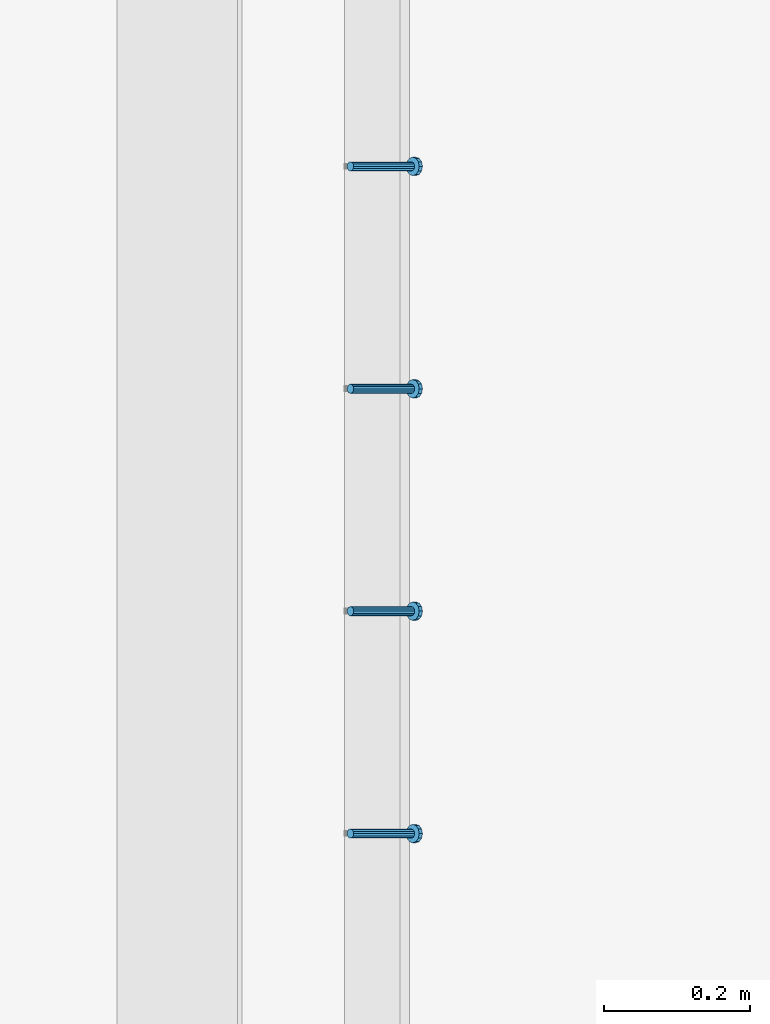
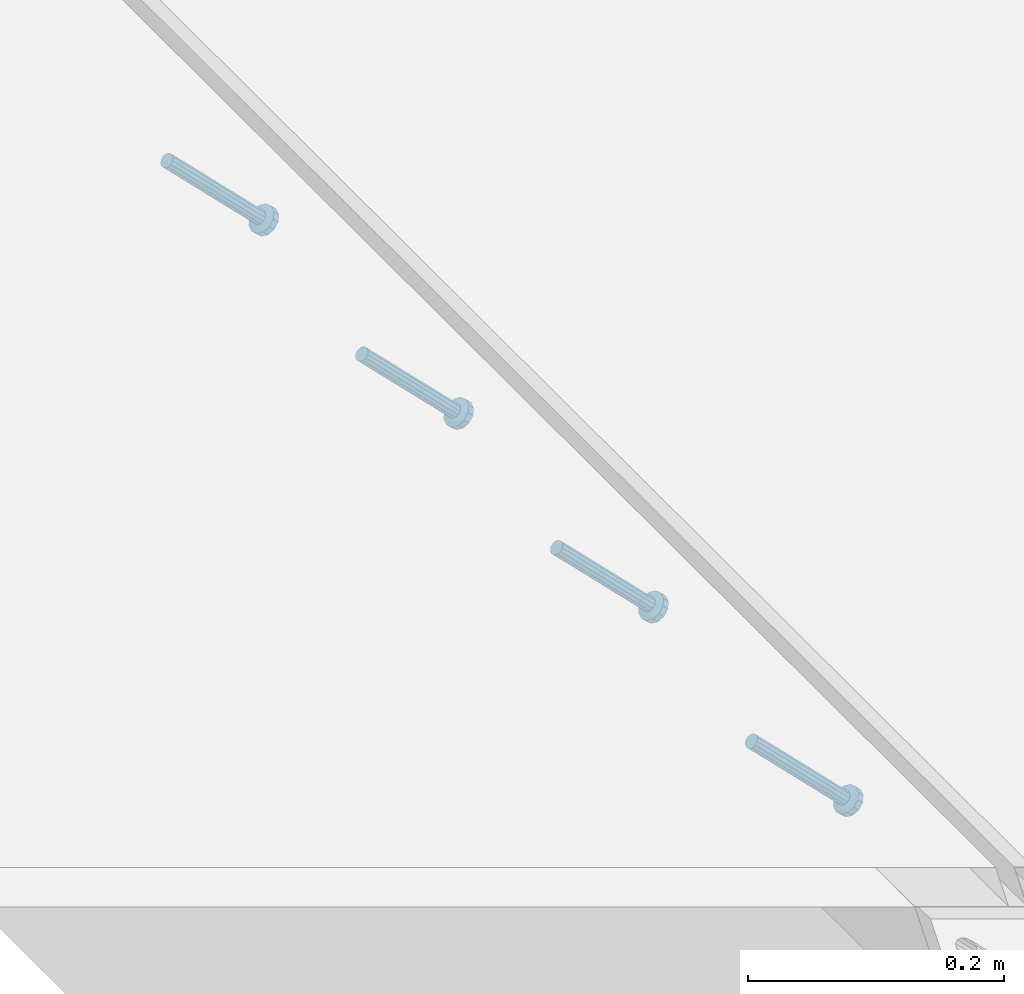
# One storey, part 2281 of 3843: 4 members, 1 element without a shape of its own.
"""IFC2X3 building model written with IfcOpenShell, lengths in millimetres."""

from ifc_helpers import new_model, si_unit, frame, origin_with_axes, place, context, subcontext, project, spatial, faceted_brep, material, type_object, element, aggregate, save


model = new_model("IFC2X3")

# Units and contexts
model_context = context("Model", 3, precision=1e-05, world=origin_with_axes())
body_context = subcontext(model_context, "Body", "Model", "MODEL_VIEW")
ifc_project = project(units=[si_unit("LENGTHUNIT", "METRE", prefix="MILLI"), si_unit("AREAUNIT", "SQUARE_METRE"), si_unit("VOLUMEUNIT", "CUBIC_METRE"), si_unit("MASSUNIT", "GRAM", prefix="KILO"), si_unit("TIMEUNIT", "SECOND"), si_unit("PLANEANGLEUNIT", "RADIAN"), si_unit("SOLIDANGLEUNIT", "STERADIAN"), si_unit("THERMODYNAMICTEMPERATUREUNIT", "DEGREE_CELSIUS"), si_unit("LUMINOUSINTENSITYUNIT", "LUMEN")], contexts=[model_context])

# Site, building, storey
site_placement = place(None, origin_with_axes())
site = spatial("IfcSite", under=ifc_project, at=site_placement, CompositionType="ELEMENT")
building_placement = place(site_placement, origin_with_axes())
building = spatial("IfcBuilding", under=site, at=building_placement, Name="Undefined", CompositionType="ELEMENT")
storey_placement = place(building_placement, origin_with_axes())
storey = spatial("IfcBuildingStorey", under=building, at=storey_placement, Name="Undefined", CompositionType="ELEMENT", Elevation=0.0)

# Assembly, members
assembly_placement = place(storey_placement, origin_with_axes())
assembly = element("IfcElementAssembly", 1, at=assembly_placement, inside=storey, Name="EMBED_ANGLE", AssemblyPlace="NOTDEFINED", PredefinedType="RIGID_FRAME")
ifc_material = material(Name="STEEL/A108")
member_type = type_object("IfcMemberType", PredefinedType="NOTDEFINED")
member_1_placement = place(assembly_placement, frame((66677.3495, 40817.800201416, 30446.6625), z_axis=(0.0, 1.0, 0.0), x_axis=(0.707106781186548, 0.0, -0.707106781186548)))
member_1 = element("IfcMember", 2, at=member_1_placement, type_object=member_type, material=ifc_material, Name="HEADED STUD ANCHOR", context=body_context, shape_type="Brep", body=[
    faceted_brep([(7.27595761418343e-12, -3.18000006675175, 5.5), (0.0, -5.49999999998363, 3.1800000667572), (118.110000000976, -5.49999999999091, 3.1800000667572), (118.110000000983, -3.18000006675175, 5.5), (0.0, -6.3499999046162, 0.0), (118.110000000968, -6.34999990461256, 0.0), (0.0, -5.49999999998363, -3.1800000667572), (118.110000000976, -5.49999999999091, -3.1800000667572), (7.27595761418343e-12, -3.18000006675175, -5.5), (118.110000000983, -3.18000006675175, -5.5), (7.27595761418343e-12, -1.81898940354586e-12, -6.34999990463257), (118.110000000968, -1.81898940354586e-12, -6.34999990463257), (0.0, 3.18000006675175, -5.5), (118.110000000968, 3.18000006674811, -5.5), (7.27595761418343e-12, 5.49999999998363, -3.1800000667572), (118.110000000983, 5.49999999998363, -3.1800000667572), (7.27595761418343e-12, 6.3499999046162, 0.0), (118.110000000976, 6.34999990461256, 0.0), (7.27595761418343e-12, 5.49999999998363, 3.1800000667572), (118.110000000983, 5.49999999998363, 3.1800000667572), (0.0, 3.18000006675175, 5.5), (118.110000000968, 3.18000006674811, 5.5), (7.27595761418343e-12, -1.81898940354586e-12, 6.34999990463257), (118.110000000968, -1.81898940354586e-12, 6.34999990463257), (120.650000000991, -10.9899997710909, 6.34999990463257), (120.650000000998, -6.34000015257152, 10.9899997711182), (120.650000000991, -12.6999998092379, 0.0), (120.650000000991, -10.9899997710909, -6.34999990463257), (120.650000000998, -6.34000015257152, -10.9899997711182), (120.650000000991, -1.81898940354586e-12, -12.6899995803833), (120.650000000991, 6.34000015257152, -10.9899997711182), (120.650000000998, 10.9899997710909, -6.34999990463257), (120.650000000991, 12.6999998092342, 0.0), (120.650000000998, 10.9899997710909, 6.34999990463257), (120.650000000991, 6.34000015257152, 10.9899997711182), (120.650000000991, -1.81898940354586e-12, 12.6899995803833), (127.000000001048, -10.9899997710945, 6.34999990463257), (127.000000001048, -6.34000015257152, 10.9899997711182), (127.000000001048, -12.6999998092342, 0.0), (127.000000001048, -10.9899997710945, -6.34999990463257), (127.000000001048, -6.34000015257152, -10.9899997711182), (127.000000001048, 1.81898940354586e-12, -12.6899995803833), (127.000000001048, 6.34000015256788, -10.9899997711182), (127.000000001048, 10.9899997710909, -6.34999990463257), (127.000000001048, 12.6999998092379, 0.0), (127.000000001048, 10.9899997710909, 6.34999990463257), (127.000000001048, 6.34000015256788, 10.9899997711182), (127.000000001048, 1.81898940354586e-12, 12.6899995803833)], [[[0, 1, 2, 3]], [[1, 4, 5, 2]], [[4, 6, 7, 5]], [[6, 8, 9, 7]], [[8, 10, 11, 9]], [[10, 12, 13, 11]], [[12, 14, 15, 13]], [[14, 16, 17, 15]], [[16, 18, 19, 17]], [[18, 20, 21, 19]], [[20, 22, 23, 21]], [[22, 0, 3, 23]], [[22, 20, 18, 16, 14, 12, 10, 8, 6, 4, 1, 0]], [[3, 2, 24, 25]], [[2, 5, 26, 24]], [[5, 7, 27, 26]], [[7, 9, 28, 27]], [[9, 11, 29, 28]], [[11, 13, 30, 29]], [[13, 15, 31, 30]], [[15, 17, 32, 31]], [[17, 19, 33, 32]], [[19, 21, 34, 33]], [[21, 23, 35, 34]], [[23, 3, 25, 35]], [[25, 24, 36, 37]], [[24, 26, 38, 36]], [[26, 27, 39, 38]], [[27, 28, 40, 39]], [[28, 29, 41, 40]], [[29, 30, 42, 41]], [[30, 31, 43, 42]], [[31, 32, 44, 43]], [[32, 33, 45, 44]], [[33, 34, 46, 45]], [[34, 35, 47, 46]], [[35, 25, 37, 47]], [[38, 39, 40, 41, 42, 43, 44, 45, 46, 47, 37, 36]]]),
])
member_2_placement = place(assembly_placement, frame((66677.3495, 41122.600201416, 30446.6625), z_axis=(0.0, 1.0, 0.0), x_axis=(0.707106781186548, 0.0, -0.707106781186548)))
member_2 = element("IfcMember", 3, at=member_2_placement, type_object=member_type, material=ifc_material, Name="HEADED STUD ANCHOR", context=body_context, shape_type="Brep", body=[
    faceted_brep([(7.27595761418343e-12, -3.18000006675175, 5.5), (0.0, -5.49999999998363, 3.1800000667572), (118.110000000976, -5.49999999999091, 3.1800000667572), (118.110000000983, -3.18000006675175, 5.5), (0.0, -6.3499999046162, 0.0), (118.110000000968, -6.34999990461256, 0.0), (0.0, -5.49999999998363, -3.1800000667572), (118.110000000976, -5.49999999999091, -3.1800000667572), (7.27595761418343e-12, -3.18000006675175, -5.5), (118.110000000983, -3.18000006675175, -5.5), (7.27595761418343e-12, -1.81898940354586e-12, -6.34999990463257), (118.110000000968, -1.81898940354586e-12, -6.34999990463257), (0.0, 3.18000006675175, -5.5), (118.110000000968, 3.18000006674811, -5.5), (7.27595761418343e-12, 5.49999999998363, -3.1800000667572), (118.110000000983, 5.49999999998363, -3.1800000667572), (7.27595761418343e-12, 6.3499999046162, 0.0), (118.110000000976, 6.34999990461256, 0.0), (7.27595761418343e-12, 5.49999999998363, 3.1800000667572), (118.110000000983, 5.49999999998363, 3.1800000667572), (0.0, 3.18000006675175, 5.5), (118.110000000968, 3.18000006674811, 5.5), (7.27595761418343e-12, -1.81898940354586e-12, 6.34999990463257), (118.110000000968, -1.81898940354586e-12, 6.34999990463257), (120.650000000991, -10.9899997710909, 6.34999990463257), (120.650000000998, -6.34000015257152, 10.9899997711182), (120.650000000991, -12.6999998092379, 0.0), (120.650000000991, -10.9899997710909, -6.34999990463257), (120.650000000998, -6.34000015257152, -10.9899997711182), (120.650000000991, -1.81898940354586e-12, -12.6899995803833), (120.650000000991, 6.34000015257152, -10.9899997711182), (120.650000000998, 10.9899997710909, -6.34999990463257), (120.650000000991, 12.6999998092342, 0.0), (120.650000000998, 10.9899997710909, 6.34999990463257), (120.650000000991, 6.34000015257152, 10.9899997711182), (120.650000000991, -1.81898940354586e-12, 12.6899995803833), (127.000000001048, -10.9899997710945, 6.34999990463257), (127.000000001048, -6.34000015257152, 10.9899997711182), (127.000000001048, -12.6999998092342, 0.0), (127.000000001048, -10.9899997710945, -6.34999990463257), (127.000000001048, -6.34000015257152, -10.9899997711182), (127.000000001048, 1.81898940354586e-12, -12.6899995803833), (127.000000001048, 6.34000015256788, -10.9899997711182), (127.000000001048, 10.9899997710909, -6.34999990463257), (127.000000001048, 12.6999998092379, 0.0), (127.000000001048, 10.9899997710909, 6.34999990463257), (127.000000001048, 6.34000015256788, 10.9899997711182), (127.000000001048, 1.81898940354586e-12, 12.6899995803833)], [[[0, 1, 2, 3]], [[1, 4, 5, 2]], [[4, 6, 7, 5]], [[6, 8, 9, 7]], [[8, 10, 11, 9]], [[10, 12, 13, 11]], [[12, 14, 15, 13]], [[14, 16, 17, 15]], [[16, 18, 19, 17]], [[18, 20, 21, 19]], [[20, 22, 23, 21]], [[22, 0, 3, 23]], [[22, 20, 18, 16, 14, 12, 10, 8, 6, 4, 1, 0]], [[3, 2, 24, 25]], [[2, 5, 26, 24]], [[5, 7, 27, 26]], [[7, 9, 28, 27]], [[9, 11, 29, 28]], [[11, 13, 30, 29]], [[13, 15, 31, 30]], [[15, 17, 32, 31]], [[17, 19, 33, 32]], [[19, 21, 34, 33]], [[21, 23, 35, 34]], [[23, 3, 25, 35]], [[25, 24, 36, 37]], [[24, 26, 38, 36]], [[26, 27, 39, 38]], [[27, 28, 40, 39]], [[28, 29, 41, 40]], [[29, 30, 42, 41]], [[30, 31, 43, 42]], [[31, 32, 44, 43]], [[32, 33, 45, 44]], [[33, 34, 46, 45]], [[34, 35, 47, 46]], [[35, 25, 37, 47]], [[38, 39, 40, 41, 42, 43, 44, 45, 46, 47, 37, 36]]]),
])
member_3_placement = place(assembly_placement, frame((66677.3495, 41427.400201416, 30446.6625), z_axis=(0.0, 1.0, 0.0), x_axis=(0.707106781186548, 0.0, -0.707106781186548)))
member_3 = element("IfcMember", 4, at=member_3_placement, type_object=member_type, material=ifc_material, Name="HEADED STUD ANCHOR", context=body_context, shape_type="Brep", body=[
    faceted_brep([(7.27595761418343e-12, -3.18000006675175, 5.5), (0.0, -5.49999999998363, 3.1800000667572), (118.110000000976, -5.49999999999091, 3.1800000667572), (118.110000000983, -3.18000006675175, 5.5), (0.0, -6.3499999046162, 0.0), (118.110000000968, -6.34999990461256, 0.0), (0.0, -5.49999999998363, -3.1800000667572), (118.110000000976, -5.49999999999091, -3.1800000667572), (7.27595761418343e-12, -3.18000006675175, -5.5), (118.110000000983, -3.18000006675175, -5.5), (7.27595761418343e-12, -1.81898940354586e-12, -6.34999990463257), (118.110000000968, -1.81898940354586e-12, -6.34999990463257), (0.0, 3.18000006675175, -5.5), (118.110000000968, 3.18000006674811, -5.5), (7.27595761418343e-12, 5.49999999998363, -3.1800000667572), (118.110000000983, 5.49999999998363, -3.1800000667572), (7.27595761418343e-12, 6.3499999046162, 0.0), (118.110000000976, 6.34999990461256, 0.0), (7.27595761418343e-12, 5.49999999998363, 3.1800000667572), (118.110000000983, 5.49999999998363, 3.1800000667572), (0.0, 3.18000006675175, 5.5), (118.110000000968, 3.18000006674811, 5.5), (7.27595761418343e-12, -1.81898940354586e-12, 6.34999990463257), (118.110000000968, -1.81898940354586e-12, 6.34999990463257), (120.650000000991, -10.9899997710909, 6.34999990463257), (120.650000000998, -6.34000015257152, 10.9899997711182), (120.650000000991, -12.6999998092379, 0.0), (120.650000000991, -10.9899997710909, -6.34999990463257), (120.650000000998, -6.34000015257152, -10.9899997711182), (120.650000000991, -1.81898940354586e-12, -12.6899995803833), (120.650000000991, 6.34000015257152, -10.9899997711182), (120.650000000998, 10.9899997710909, -6.34999990463257), (120.650000000991, 12.6999998092342, 0.0), (120.650000000998, 10.9899997710909, 6.34999990463257), (120.650000000991, 6.34000015257152, 10.9899997711182), (120.650000000991, -1.81898940354586e-12, 12.6899995803833), (127.000000001048, -10.9899997710945, 6.34999990463257), (127.000000001048, -6.34000015257152, 10.9899997711182), (127.000000001048, -12.6999998092342, 0.0), (127.000000001048, -10.9899997710945, -6.34999990463257), (127.000000001048, -6.34000015257152, -10.9899997711182), (127.000000001048, 1.81898940354586e-12, -12.6899995803833), (127.000000001048, 6.34000015256788, -10.9899997711182), (127.000000001048, 10.9899997710909, -6.34999990463257), (127.000000001048, 12.6999998092379, 0.0), (127.000000001048, 10.9899997710909, 6.34999990463257), (127.000000001048, 6.34000015256788, 10.9899997711182), (127.000000001048, 1.81898940354586e-12, 12.6899995803833)], [[[0, 1, 2, 3]], [[1, 4, 5, 2]], [[4, 6, 7, 5]], [[6, 8, 9, 7]], [[8, 10, 11, 9]], [[10, 12, 13, 11]], [[12, 14, 15, 13]], [[14, 16, 17, 15]], [[16, 18, 19, 17]], [[18, 20, 21, 19]], [[20, 22, 23, 21]], [[22, 0, 3, 23]], [[22, 20, 18, 16, 14, 12, 10, 8, 6, 4, 1, 0]], [[3, 2, 24, 25]], [[2, 5, 26, 24]], [[5, 7, 27, 26]], [[7, 9, 28, 27]], [[9, 11, 29, 28]], [[11, 13, 30, 29]], [[13, 15, 31, 30]], [[15, 17, 32, 31]], [[17, 19, 33, 32]], [[19, 21, 34, 33]], [[21, 23, 35, 34]], [[23, 3, 25, 35]], [[25, 24, 36, 37]], [[24, 26, 38, 36]], [[26, 27, 39, 38]], [[27, 28, 40, 39]], [[28, 29, 41, 40]], [[29, 30, 42, 41]], [[30, 31, 43, 42]], [[31, 32, 44, 43]], [[32, 33, 45, 44]], [[33, 34, 46, 45]], [[34, 35, 47, 46]], [[35, 25, 37, 47]], [[38, 39, 40, 41, 42, 43, 44, 45, 46, 47, 37, 36]]]),
])
member_4_placement = place(assembly_placement, frame((66677.3495, 41732.200201416, 30446.6625), z_axis=(0.0, 1.0, 0.0), x_axis=(0.707106781186548, 0.0, -0.707106781186548)))
member_4 = element("IfcMember", 5, at=member_4_placement, type_object=member_type, material=ifc_material, Name="HEADED STUD ANCHOR", context=body_context, shape_type="Brep", body=[
    faceted_brep([(7.27595761418343e-12, -3.18000006675175, 5.5), (0.0, -5.49999999998363, 3.1800000667572), (118.110000000976, -5.49999999999091, 3.1800000667572), (118.110000000983, -3.18000006675175, 5.5), (0.0, -6.3499999046162, 0.0), (118.110000000968, -6.34999990461256, 0.0), (0.0, -5.49999999998363, -3.1800000667572), (118.110000000976, -5.49999999999091, -3.1800000667572), (7.27595761418343e-12, -3.18000006675175, -5.5), (118.110000000983, -3.18000006675175, -5.5), (7.27595761418343e-12, -1.81898940354586e-12, -6.34999990463257), (118.110000000968, -1.81898940354586e-12, -6.34999990463257), (0.0, 3.18000006675175, -5.5), (118.110000000968, 3.18000006674811, -5.5), (7.27595761418343e-12, 5.49999999998363, -3.1800000667572), (118.110000000983, 5.49999999998363, -3.1800000667572), (7.27595761418343e-12, 6.3499999046162, 0.0), (118.110000000976, 6.34999990461256, 0.0), (7.27595761418343e-12, 5.49999999998363, 3.1800000667572), (118.110000000983, 5.49999999998363, 3.1800000667572), (0.0, 3.18000006675175, 5.5), (118.110000000968, 3.18000006674811, 5.5), (7.27595761418343e-12, -1.81898940354586e-12, 6.34999990463257), (118.110000000968, -1.81898940354586e-12, 6.34999990463257), (120.650000000991, -10.9899997710909, 6.34999990463257), (120.650000000998, -6.34000015257152, 10.9899997711182), (120.650000000991, -12.6999998092379, 0.0), (120.650000000991, -10.9899997710909, -6.34999990463257), (120.650000000998, -6.34000015257152, -10.9899997711182), (120.650000000991, -1.81898940354586e-12, -12.6899995803833), (120.650000000991, 6.34000015257152, -10.9899997711182), (120.650000000998, 10.9899997710909, -6.34999990463257), (120.650000000991, 12.6999998092342, 0.0), (120.650000000998, 10.9899997710909, 6.34999990463257), (120.650000000991, 6.34000015257152, 10.9899997711182), (120.650000000991, -1.81898940354586e-12, 12.6899995803833), (127.000000001048, -10.9899997710945, 6.34999990463257), (127.000000001048, -6.34000015257152, 10.9899997711182), (127.000000001048, -12.6999998092342, 0.0), (127.000000001048, -10.9899997710945, -6.34999990463257), (127.000000001048, -6.34000015257152, -10.9899997711182), (127.000000001048, 1.81898940354586e-12, -12.6899995803833), (127.000000001048, 6.34000015256788, -10.9899997711182), (127.000000001048, 10.9899997710909, -6.34999990463257), (127.000000001048, 12.6999998092379, 0.0), (127.000000001048, 10.9899997710909, 6.34999990463257), (127.000000001048, 6.34000015256788, 10.9899997711182), (127.000000001048, 1.81898940354586e-12, 12.6899995803833)], [[[0, 1, 2, 3]], [[1, 4, 5, 2]], [[4, 6, 7, 5]], [[6, 8, 9, 7]], [[8, 10, 11, 9]], [[10, 12, 13, 11]], [[12, 14, 15, 13]], [[14, 16, 17, 15]], [[16, 18, 19, 17]], [[18, 20, 21, 19]], [[20, 22, 23, 21]], [[22, 0, 3, 23]], [[22, 20, 18, 16, 14, 12, 10, 8, 6, 4, 1, 0]], [[3, 2, 24, 25]], [[2, 5, 26, 24]], [[5, 7, 27, 26]], [[7, 9, 28, 27]], [[9, 11, 29, 28]], [[11, 13, 30, 29]], [[13, 15, 31, 30]], [[15, 17, 32, 31]], [[17, 19, 33, 32]], [[19, 21, 34, 33]], [[21, 23, 35, 34]], [[23, 3, 25, 35]], [[25, 24, 36, 37]], [[24, 26, 38, 36]], [[26, 27, 39, 38]], [[27, 28, 40, 39]], [[28, 29, 41, 40]], [[29, 30, 42, 41]], [[30, 31, 43, 42]], [[31, 32, 44, 43]], [[32, 33, 45, 44]], [[33, 34, 46, 45]], [[34, 35, 47, 46]], [[35, 25, 37, 47]], [[38, 39, 40, 41, 42, 43, 44, 45, 46, 47, 37, 36]]]),
])
aggregate(assembly, [member_1, member_2, member_3, member_4])

save(model, "model.ifc")
